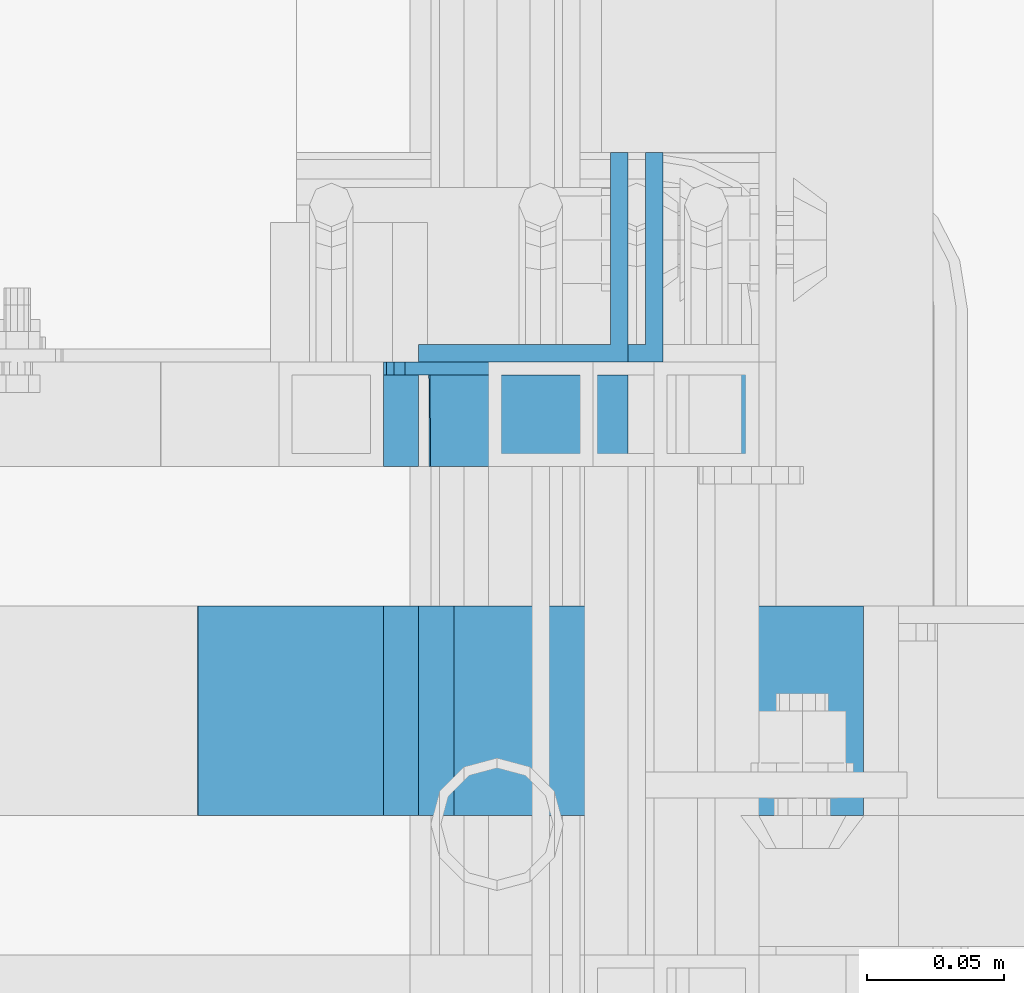
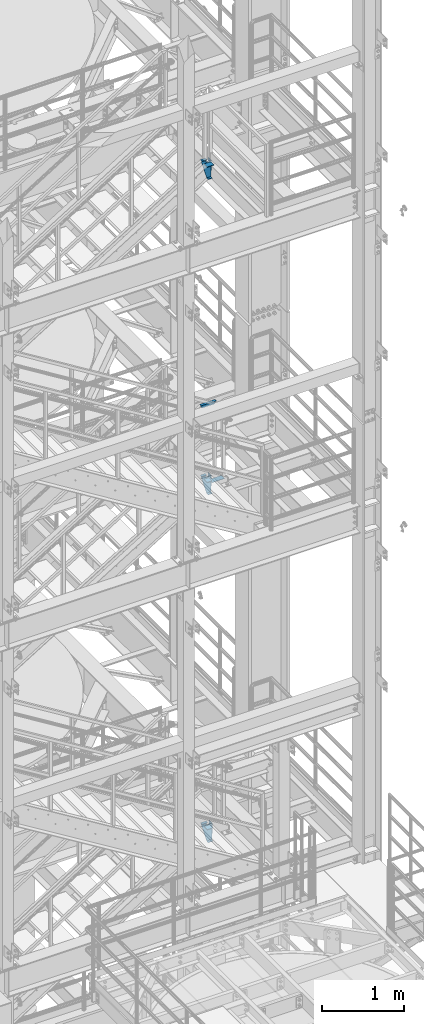
# One storey, part 1199 of 1876: 11 beams, 8 elements without a shape of their own.
"""IFC2X3 building model written with IfcOpenShell, lengths in millimetres."""

from ifc_helpers import new_model, si_unit, frame, origin_with_axes, place, context, subcontext, project, spatial, faceted_brep, material, type_object, element, aggregate, save


model = new_model("IFC2X3")

# Units and contexts
model_context = context("Model", 3, precision=1e-05, world=origin_with_axes())
body_context = subcontext(model_context, "Body", "Model", "MODEL_VIEW")
ifc_project = project(units=[si_unit("LENGTHUNIT", "METRE", prefix="MILLI"), si_unit("AREAUNIT", "SQUARE_METRE"), si_unit("VOLUMEUNIT", "CUBIC_METRE"), si_unit("MASSUNIT", "GRAM", prefix="KILO"), si_unit("TIMEUNIT", "SECOND"), si_unit("PLANEANGLEUNIT", "RADIAN"), si_unit("SOLIDANGLEUNIT", "STERADIAN"), si_unit("THERMODYNAMICTEMPERATUREUNIT", "DEGREE_CELSIUS"), si_unit("LUMINOUSINTENSITYUNIT", "LUMEN")], contexts=[model_context])

# Site, building, storey
site_placement = place(None, origin_with_axes())
site = spatial("IfcSite", under=ifc_project, at=site_placement, CompositionType="ELEMENT")
building_placement = place(site_placement, origin_with_axes())
building = spatial("IfcBuilding", under=site, at=building_placement, Name="Undefined", CompositionType="ELEMENT")
storey_placement = place(building_placement, origin_with_axes())
storey = spatial("IfcBuildingStorey", under=building, at=storey_placement, Name="Undefined", CompositionType="ELEMENT", Elevation=0.0)

# Assembly, beam
assembly_1_placement = place(storey_placement, origin_with_axes())
assembly_1 = element("IfcElementAssembly", 1, at=assembly_1_placement, inside=storey, Name="RAIL", AssemblyPlace="NOTDEFINED", PredefinedType="RIGID_FRAME")
ifc_material_1 = material()
beam_type_1 = type_object("IfcBeamType", Name="HSS1-1/2X1-1/2X1/8", PredefinedType="NOTDEFINED")
beam_1_placement = place(assembly_1_placement, frame((6273.80000001181, -5734.05000114554, 14376.4000000019), z_axis=(0.0, 0.0, -1.0), x_axis=(-1.0, 0.0, 0.0)))
beam_1 = element("IfcBeam", 2, at=beam_1_placement, type_object=beam_type_1, material=ifc_material_1, Name="RAIL", ObjectType="HSS1-1/2X1-1/2X1/8", context=body_context, shape_type="Brep", body=[
    faceted_brep([(-15.875, 15.8749981318675, -15.875), (-15.875, -15.8750000000011, -15.875), (197.775835100124, -15.8749992829999, -15.8749992829999), (197.775835100124, 15.8749992829999, -15.8749992829999), (15.875, -15.8750000000011, 15.875), (188.792145247951, -15.8749992829999, 15.8749992829999), (15.875, 15.8749981318675, 15.875), (188.792145247951, 15.8749992829999, 15.8749992829999), (-19.049999234363, 19.0499992349996, -19.0499992350001), (19.0500000000002, 19.0499992349996, 19.0499992350001), (187.893776235741, 19.0499992349996, 19.0499992349996), (198.674204112334, 19.0499992349996, -19.0499992349996), (19.0500000000002, -19.0499992349996, 19.0499992350001), (187.893776235741, -19.0499992349996, 19.0499992349996), (-19.049999234363, -19.0499992349996, -19.0499992350001), (198.674204112334, -19.0499992349996, -19.0499992349996)], [[[0, 1, 2, 3]], [[1, 4, 5, 2]], [[4, 6, 7, 5]], [[6, 0, 3, 7]], [[8, 9, 10, 11]], [[9, 12, 13, 10]], [[12, 14, 15, 13]], [[14, 8, 11, 15]], [[13, 15, 11, 10], [5, 7, 3, 2]], [[14, 12, 9, 8], [6, 4, 1, 0]]]),
])
aggregate(assembly_1, [beam_1])

assembly_2_placement = place(storey_placement, origin_with_axes())
assembly_2 = element("IfcElementAssembly", 3, at=assembly_2_placement, inside=storey, Name="ref.", AssemblyPlace="NOTDEFINED", PredefinedType="RIGID_FRAME")
ifc_material_2 = material(Name="STEEL/Steel_Undefined")
beam_type_2 = type_object("IfcBeamType", PredefinedType="NOTDEFINED")
beam_2_placement = place(assembly_2_placement, frame((6156.32500000113, -5842.00000114094, 13306.425), z_axis=(0.0, -1.0, 0.0), x_axis=(1.0, 0.0, 0.0)))
beam_2 = element("IfcBeam", 4, at=beam_2_placement, type_object=beam_type_2, material=ifc_material_2, Name="ref.", context=body_context, shape_type="Brep", body=[
    faceted_brep([(0.0, 3.17500000000018, -38.1000000000004), (0.0, 3.17500000000018, 38.1000000000004), (174.624999999249, 3.17500000000018, 38.1000000000004), (174.624999999249, 3.17500000000018, -38.1000000000004), (0.0, -3.17500000000018, 38.1000000000004), (174.624999999249, -3.17500000000018, 38.1000000000004), (0.0, -3.17500000000018, -38.1000000000004), (174.624999999249, -3.17500000000018, -38.1000000000004)], [[[0, 1, 2, 3]], [[1, 4, 5, 2]], [[4, 6, 7, 5]], [[6, 0, 3, 7]], [[5, 7, 3, 2]], [[6, 4, 1, 0]]]),
])
aggregate(assembly_2, [beam_2])

assembly_3_placement = place(storey_placement, origin_with_axes())
assembly_3 = element("IfcElementAssembly", 5, at=assembly_3_placement, inside=storey, Name="ref.", AssemblyPlace="NOTDEFINED", PredefinedType="RIGID_FRAME")
beam_3_placement = place(assembly_3_placement, frame((6088.76955395294, -5842.00000114554, 18005.4250004543), z_axis=(0.0, -1.0, 0.0), x_axis=(1.0, 0.0, 0.0)))
beam_3 = element("IfcBeam", 6, at=beam_3_placement, type_object=beam_type_2, material=ifc_material_2, Name="ref.", context=body_context, shape_type="Brep", body=[
    faceted_brep([(0.0, 3.17500000000018, -38.1000000000004), (0.0, 3.17500000000018, 38.1000000000004), (93.1899044672018, 3.17499999995925, 38.1000000000004), (93.1899044672018, 3.17499999995925, -38.1000000000004), (0.0, -3.17500000000018, 38.1000000000004), (93.1899044671982, -3.17500000003929, 38.1000000000004), (0.0, -3.17500000000018, -38.1000000000004), (93.1899044671982, -3.17500000003929, -38.1000000000004)], [[[0, 1, 2, 3]], [[1, 4, 5, 2]], [[4, 6, 7, 5]], [[6, 0, 3, 7]], [[5, 7, 3, 2]], [[6, 4, 1, 0]]]),
])
aggregate(assembly_3, [beam_3])

assembly_4_placement = place(storey_placement, origin_with_axes())
assembly_4 = element("IfcElementAssembly", 7, at=assembly_4_placement, inside=storey, Name="ref.", AssemblyPlace="NOTDEFINED", PredefinedType="RIGID_FRAME")
beam_4_placement = place(assembly_4_placement, frame((6088.60349624803, -5842.00000113861, 8185.14999914302), z_axis=(0.0, -1.0, 0.0), x_axis=(1.0, 0.0, 0.0)))
beam_4 = element("IfcBeam", 8, at=beam_4_placement, type_object=beam_type_2, material=ifc_material_2, Name="ref.", context=body_context, shape_type="Brep", body=[
    faceted_brep([(0.0, 3.17500000000018, -38.1000000000004), (0.0, 3.17500000000018, 38.1000000000004), (80.4006198193201, 3.17499999997017, 38.1000000000004), (80.4006198193201, 3.17499999997017, -38.1000000000004), (0.0, -3.17500000000018, 38.1000000000004), (80.4006198193183, -3.17500000002929, 38.1000000000004), (0.0, -3.17500000000018, -38.1000000000004), (80.4006198193183, -3.17500000002929, -38.1000000000004)], [[[0, 1, 2, 3]], [[1, 4, 5, 2]], [[4, 6, 7, 5]], [[6, 0, 3, 7]], [[5, 7, 3, 2]], [[6, 4, 1, 0]]]),
])
aggregate(assembly_4, [beam_4])

assembly_5_placement = place(storey_placement, origin_with_axes())
assembly_5 = element("IfcElementAssembly", 9, at=assembly_5_placement, inside=storey, Name="STRINGER", AssemblyPlace="NOTDEFINED", PredefinedType="RIGID_FRAME")
ifc_material_3 = material(Name="STEEL/A36")
beam_type_3 = type_object("IfcBeamType", Name="L3X3X1/4", PredefinedType="NOTDEFINED")
beam_5_placement = place(assembly_5_placement, frame((6207.12500000155, -5676.90000115659, 17954.6250011493), z_axis=(-1.0, 0.0, 0.0), x_axis=(0.0, 0.0, -1.0)))
beam_5 = element("IfcBeam", 10, at=beam_5_placement, type_object=beam_type_3, material=ifc_material_3, Name="ANGLE", ObjectType="L3X3X1/4", context=body_context, shape_type="Brep", body=[
    faceted_brep([(0.0, 38.1000000000004, -38.1), (0.0, 38.1000000000004, 38.1), (152.4, 38.1000000000004, 38.1), (152.4, 38.1000000000004, -38.1), (0.0, 31.75, 38.1000000000004), (152.4, 31.75, 38.0999999999999), (0.0, 31.75, -31.75), (152.4, 31.75, -31.75), (0.0, -38.1000000000004, -31.75), (152.4, -38.1000000000004, -31.75), (0.0, -38.1000000000004, -38.1), (152.4, -38.1000000000004, -38.1)], [[[0, 1, 2, 3]], [[1, 4, 5, 2]], [[4, 6, 7, 5]], [[6, 8, 9, 7]], [[8, 10, 11, 9]], [[10, 0, 3, 11]], [[5, 7, 9, 11, 3, 2]], [[10, 8, 6, 4, 1, 0]]]),
])

assembly_6_placement = place(storey_placement, origin_with_axes())
assembly_6 = element("IfcElementAssembly", 11, at=assembly_6_placement, inside=storey, Name="STRINGER", AssemblyPlace="NOTDEFINED", PredefinedType="RIGID_FRAME")
beam_6_placement = place(assembly_6_placement, frame((6207.12500000162, -5676.9000011517, 13281.0250000069), z_axis=(-1.0, 0.0, 0.0), x_axis=(0.0, 0.0, -1.0)))
beam_6 = element("IfcBeam", 12, at=beam_6_placement, type_object=beam_type_3, material=ifc_material_3, Name="ANGLE", ObjectType="L3X3X1/4", context=body_context, shape_type="Brep", body=[
    faceted_brep([(0.0, 38.1000000000004, -38.1), (0.0, 38.1000000000004, 38.1), (152.4, 38.1000000000004, 38.1), (152.4, 38.1000000000004, -38.1), (0.0, 31.75, 38.1000000000004), (152.4, 31.75, 38.0999999999999), (0.0, 31.75, -31.75), (152.4, 31.75, -31.75), (0.0, -38.1000000000004, -31.75), (152.4, -38.1000000000004, -31.75), (0.0, -38.1000000000004, -38.1), (152.4, -38.1000000000004, -38.1)], [[[0, 1, 2, 3]], [[1, 4, 5, 2]], [[4, 6, 7, 5]], [[6, 8, 9, 7]], [[8, 10, 11, 9]], [[10, 0, 3, 11]], [[5, 7, 9, 11, 3, 2]], [[10, 8, 6, 4, 1, 0]]]),
])

assembly_7_placement = place(storey_placement, origin_with_axes())
assembly_7 = element("IfcElementAssembly", 13, at=assembly_7_placement, inside=storey, Name="STRINGER", AssemblyPlace="NOTDEFINED", PredefinedType="RIGID_FRAME")
beam_7_placement = place(assembly_7_placement, frame((6219.825, -5676.90000113597, 8124.82499862689), z_axis=(-1.0, 0.0, 0.0), x_axis=(0.0, 0.0, -1.0)))
beam_7 = element("IfcBeam", 14, at=beam_7_placement, type_object=beam_type_3, material=ifc_material_3, Name="ANGLE", ObjectType="L3X3X1/4", context=body_context, shape_type="Brep", body=[
    faceted_brep([(0.0, 38.1000000000004, -38.1), (0.0, 38.1000000000004, 38.1), (152.4, 38.1000000000004, 38.1), (152.4, 38.1000000000004, -38.1), (0.0, 31.75, 38.1000000000004), (152.4, 31.75, 38.0999999999999), (0.0, 31.75, -31.75), (152.4, 31.75, -31.75), (0.0, -38.1000000000004, -31.75), (152.4, -38.1000000000004, -31.75), (0.0, -38.1000000000004, -38.1), (152.4, -38.1000000000004, -38.1)], [[[0, 1, 2, 3]], [[1, 4, 5, 2]], [[4, 6, 7, 5]], [[6, 8, 9, 7]], [[8, 10, 11, 9]], [[10, 0, 3, 11]], [[5, 7, 9, 11, 3, 2]], [[10, 8, 6, 4, 1, 0]]]),
])

# Beam
beam_type_4 = type_object("IfcBeamType", Name="MC12X10.6", PredefinedType="NOTDEFINED")
beam_8_placement = place(assembly_5_placement, frame((6088.76955352563, -5734.05000115844, 17865.7250011493), z_axis=(0.0, 0.0, 1.0), x_axis=(1.0, 0.0, 0.0)))
beam_8 = element("IfcBeam", 15, at=beam_8_placement, type_object=beam_type_4, material=ifc_material_3, Name="STRINGER", ObjectType="MC12X10.6", context=body_context, shape_type="Brep", body=[
    faceted_brep([(67.5554464743664, -19.0500000000002, 152.400000000001), (67.5554464743664, -19.0500000000002, 144.841595000002), (67.5554464743664, 14.2875000000004, 144.17817875), (67.5554464743664, 14.2875000000004, 107.949999809265), (67.5554464743664, 19.0500000000002, 107.949999809265), (67.5554464743664, 19.0500000000002, 152.400000000001), (68.5221763969539, 14.2875000000004, 103.089920291219), (68.5221763969539, 19.0500000000002, 103.089920291219), (71.2751902974323, 14.2875000000004, 98.9697438230651), (71.2751902974323, 19.0500000000002, 98.9697438230651), (75.395366765586, 14.2875000000004, 96.2167299225875), (75.395366765586, 19.0500000000002, 96.2167299225875), (80.2554462836315, 14.2875000000004, 95.25), (80.2554462836315, 19.0500000000002, 95.25), (143.755446475915, 14.2875000000004, 95.25), (143.755446475915, 19.0500000000002, 95.25), (86.7653251990796, -19.0500000000002, -152.400000000001), (84.6137258534154, -19.0500000000002, -144.841595000002), (84.4248756966153, 14.2875000000004, -144.17817875), (2.34044781598368, 14.2875000000004, 144.17817875), (2.15159765918452, -19.0500000000002, 144.841595000002), (-1.68647966347635e-06, -19.0500000000002, 152.400000000001), (-1.68647966347635e-06, 19.0500000000002, 152.400000000001), (86.7653251990796, 19.0500000000002, -152.400000000001), (143.755446475915, 19.0500000000002, -152.400000000001), (143.755446475915, -19.0500000000002, -152.400000000001), (143.755446475915, -19.0500000000002, -144.841595000002), (143.755446475915, 14.2875000000004, -144.17817875)], [[[0, 1, 2, 3, 4, 5]], [[6, 7, 4, 3]], [[8, 9, 7, 6]], [[10, 11, 9, 8]], [[12, 13, 11, 10]], [[14, 15, 13, 12]], [[16, 17, 18, 19, 20, 21, 22, 23]], [[16, 23, 24, 25]], [[17, 16, 25, 26]], [[18, 17, 26, 27]], [[10, 8, 6, 3, 2, 19, 18, 27, 14, 12]], [[20, 19, 2, 1]], [[21, 20, 1, 0]], [[22, 21, 0, 5]], [[24, 23, 22, 5, 4, 7, 9, 11, 13, 15]], [[27, 26, 25, 24, 15, 14]]]),
])

aggregate(assembly_5, [beam_5, beam_8])

beam_9_placement = place(assembly_6_placement, frame((6088.81304778072, -5734.05000115575, 13192.1250000068), z_axis=(0.0, 0.0, 1.0), x_axis=(1.0, 0.0, 0.0)))
beam_9 = element("IfcBeam", 16, at=beam_9_placement, type_object=beam_type_4, material=ifc_material_3, Name="STRINGER", ObjectType="MC12X10.6", context=body_context, shape_type="Brep", body=[
    faceted_brep([(67.5119522192826, -19.0500000000002, 152.4), (67.5119522192826, -19.0500000000002, 144.841595), (67.5119522192826, 14.2875000000004, 144.17817875), (67.5119522192826, 14.2875000000004, 107.949999809267), (67.5119522192826, 19.0500000000002, 107.949999809267), (67.5119522192826, 19.0500000000002, 152.4), (68.4786821418702, 14.2875000000004, 103.089920291221), (68.4786821418702, 19.0500000000002, 103.089920291221), (71.2316960423486, 14.2875000000004, 98.9697438230669), (71.2316960423486, 19.0500000000002, 98.9697438230669), (75.3518725105023, 14.2875000000004, 96.2167299225894), (75.3518725105023, 19.0500000000002, 96.2167299225894), (80.2119520285478, 14.2875000000004, 95.2500000000018), (80.2119520285478, 19.0500000000002, 95.2500000000018), (143.711952220902, 14.2875000000004, 95.2500000000018), (143.711952220902, 19.0500000000002, 95.2500000000018), (86.2434264885869, -19.0500000000002, -152.4), (84.1047691857857, -19.0500000000002, -144.841595), (83.9170549778464, 14.2875000000004, -144.17817875), (2.32637152326242, 14.2875000000004, 144.17817875), (2.13865731532314, -19.0500000000002, 144.841595), (-1.68647966347635e-06, -19.0500000000002, 152.400000000001), (-1.68647966347635e-06, 19.0500000000002, 152.400000000001), (86.2434264885869, 19.0500000000002, -152.4), (143.711952220902, 19.0500000000002, -152.4), (143.711952220902, -19.0500000000002, -152.4), (143.711952220902, -19.0500000000002, -144.841595), (143.711952220902, 14.2875000000004, -144.17817875)], [[[0, 1, 2, 3, 4, 5]], [[6, 7, 4, 3]], [[8, 9, 7, 6]], [[10, 11, 9, 8]], [[12, 13, 11, 10]], [[14, 15, 13, 12]], [[16, 17, 18, 19, 20, 21, 22, 23]], [[16, 23, 24, 25]], [[17, 16, 25, 26]], [[18, 17, 26, 27]], [[10, 8, 6, 3, 2, 19, 18, 27, 14, 12]], [[20, 19, 2, 1]], [[21, 20, 1, 0]], [[22, 21, 0, 5]], [[24, 23, 22, 5, 4, 7, 9, 11, 13, 15]], [[27, 26, 25, 24, 15, 14]]]),
])

aggregate(assembly_6, [beam_6, beam_9])

beam_10_placement = place(assembly_7_placement, frame((6088.58261883853, -5734.05000113597, 8035.92499862689), z_axis=(0.0, 0.0, 1.0), x_axis=(1.0, 0.0, 0.0)))
beam_10 = element("IfcBeam", 17, at=beam_10_placement, type_object=beam_type_4, material=ifc_material_3, Name="STRINGER", ObjectType="MC12X10.6", context=body_context, shape_type="Brep", body=[
    faceted_brep([(80.4423811614652, -19.0500000000002, 152.4), (80.4423811614652, -19.0500000000002, 144.841595), (80.4423811614652, 14.2875000000004, 144.17817875), (80.4423811614652, 14.2875000000004, 107.949999809265), (80.4423811614652, 19.0500000000002, 107.949999809265), (80.4423811614652, 19.0500000000002, 152.4), (81.4091110840527, 14.2875000000004, 103.08992029122), (81.4091110840527, 19.0500000000002, 103.08992029122), (84.1621249845311, 14.2875000000004, 98.969743823066), (84.1621249845311, 19.0500000000002, 98.969743823066), (88.2823014526848, 14.2875000000004, 96.2167299225875), (88.2823014526848, 19.0500000000002, 96.2167299225875), (93.1423809707303, 14.2875000000004, 95.25), (93.1423809707303, 19.0500000000002, 95.25), (156.642381161465, 14.2875000000004, 95.25), (156.642381161465, 19.0500000000002, 95.25), (88.7788462035742, -19.0500000000002, -152.4), (86.577833470209, -19.0500000000002, -144.841595), (86.3846462020265, 14.2875000000004, -144.17817875), (2.41507661633477, 14.2875000000004, 144.17817875), (2.22188934815131, -19.0500000000002, 144.841595), (0.0208766147861752, -19.0500000000002, 152.4), (0.0208766147861752, 19.0500000000002, 152.4), (88.7788462035742, 19.0500000000002, -152.4), (156.642381161465, 19.0500000000002, -152.4), (156.642381161465, -19.0500000000002, -152.4), (156.642381161465, -19.0500000000002, -144.841595), (156.642381161465, 14.2875000000004, -144.17817875)], [[[0, 1, 2, 3, 4, 5]], [[6, 7, 4, 3]], [[8, 9, 7, 6]], [[10, 11, 9, 8]], [[12, 13, 11, 10]], [[14, 15, 13, 12]], [[16, 17, 18, 19, 20, 21, 22, 23]], [[16, 23, 24, 25]], [[17, 16, 25, 26]], [[18, 17, 26, 27]], [[10, 8, 6, 3, 2, 19, 18, 27, 14, 12]], [[20, 19, 2, 1]], [[21, 20, 1, 0]], [[22, 21, 0, 5]], [[24, 23, 22, 5, 4, 7, 9, 11, 13, 15]], [[27, 26, 25, 24, 15, 14]]]),
])

aggregate(assembly_7, [beam_7, beam_10])

# Assembly, beam
assembly_8_placement = place(storey_placement, origin_with_axes())
assembly_8 = element("IfcElementAssembly", 18, at=assembly_8_placement, inside=storey, Name="ref.", AssemblyPlace="NOTDEFINED", PredefinedType="RIGID_FRAME")
beam_type_5 = type_object("IfcBeamType", PredefinedType="NOTDEFINED")
beam_11_placement = place(assembly_8_placement, frame((6088.81304778128, -5842.00000114094, 13331.8250000034), z_axis=(0.0, -1.0, 0.0), x_axis=(1.0, 0.0, 0.0)))
beam_11 = element("IfcBeam", 19, at=beam_11_placement, type_object=beam_type_5, material=ifc_material_2, Name="ref.", context=body_context, shape_type="Brep", body=[
    faceted_brep([(0.0, 3.17500000000018, -38.1000000000004), (0.0, 3.17500000000018, 38.1000000000004), (67.5119522335917, 3.17499999999927, 38.1000000000004), (67.5119522335917, 3.17499999999927, -38.1000000000004), (0.0, -3.17500000000018, 38.1000000000004), (67.5119522335917, -3.17499999999927, 38.1000000000004), (0.0, -3.17500000000018, -38.1000000000004), (67.5119522335917, -3.17499999999927, -38.1000000000004)], [[[0, 1, 2, 3]], [[1, 4, 5, 2]], [[4, 6, 7, 5]], [[6, 0, 3, 7]], [[5, 7, 3, 2]], [[6, 4, 1, 0]]]),
])
aggregate(assembly_8, [beam_11])

save(model, "model.ifc")
